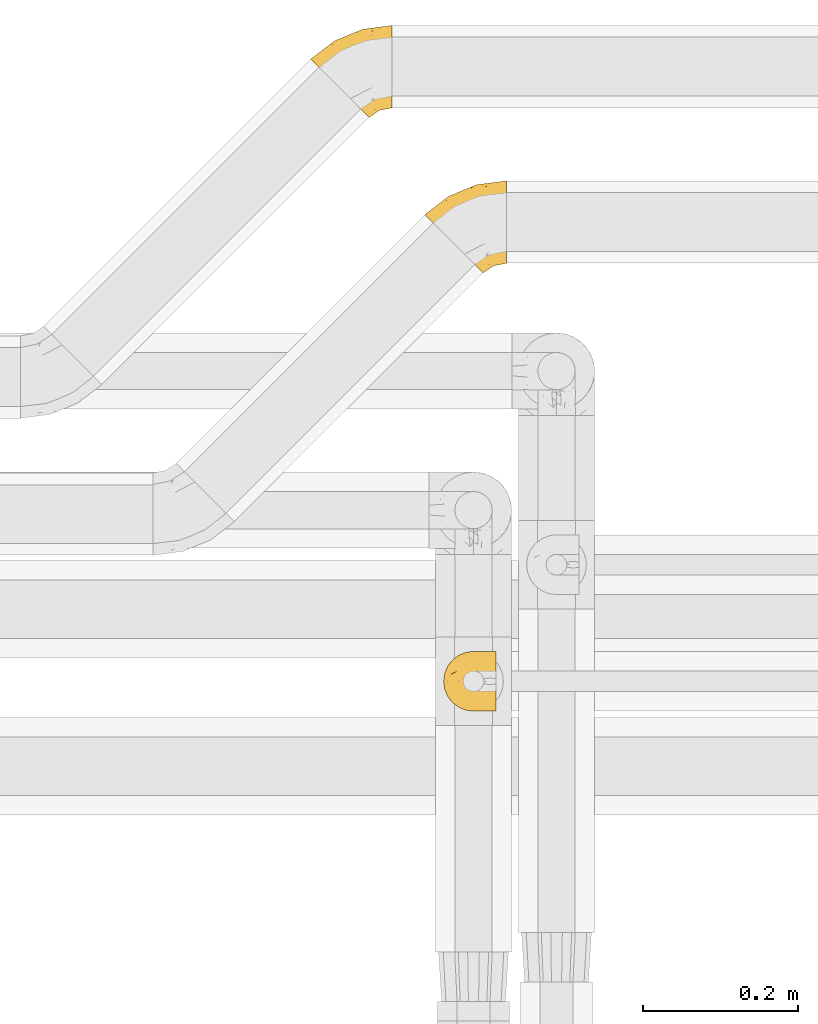
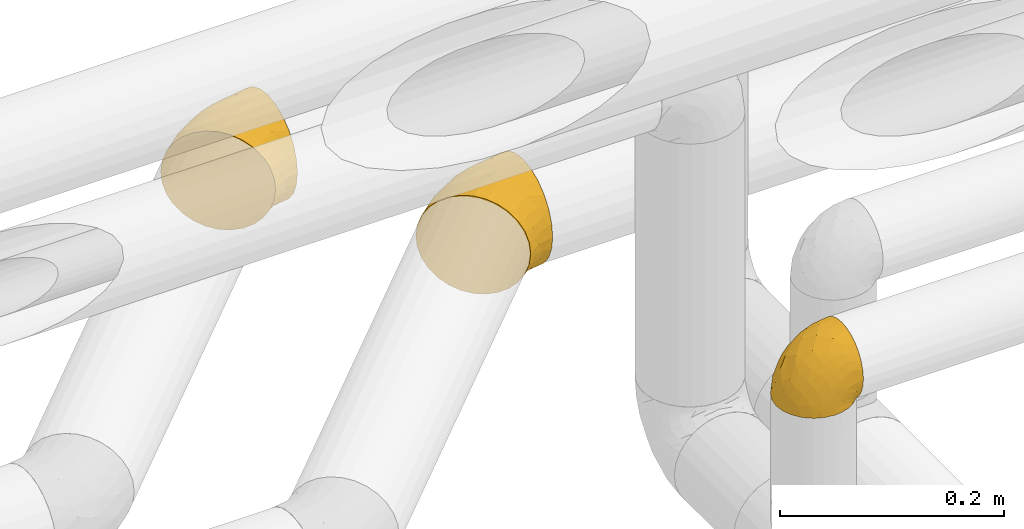
# One storey, part 375 of 827: 3 coverings.
"""IFC2X3 building model written with IfcOpenShell, lengths in millimetres."""

from ifc_helpers import new_model, entity, si_unit, converted_unit, derived_unit, direction, frame, origin, place, context, subcontext, project, spatial, faceted_brep, element, save


model = new_model("IFC2X3")

# Units and contexts
model_context = context("Model", 3, precision=0.01, world=origin(), true_north=direction((6.12303176911189e-17, 1.0)))
body_context = subcontext(model_context, "Body", "Model", "MODEL_VIEW")
ifc_project = project(units=[si_unit("LENGTHUNIT", "METRE", prefix="MILLI"), si_unit("AREAUNIT", "SQUARE_METRE"), si_unit("VOLUMEUNIT", "CUBIC_METRE"), converted_unit("PLANEANGLEUNIT", "DEGREE", entity("IfcRatioMeasure", 0.0174532925199433), si_unit("PLANEANGLEUNIT", "RADIAN"), dimensions=[0, 0, 0, 0, 0, 0, 0]), si_unit("MASSUNIT", "GRAM", prefix="KILO"), derived_unit("MASSDENSITYUNIT", [(si_unit("MASSUNIT", "GRAM", prefix="KILO"), 1), (si_unit("LENGTHUNIT", "METRE"), -3)]), derived_unit("MOMENTOFINERTIAUNIT", [(si_unit("LENGTHUNIT", "METRE"), 4)]), si_unit("TIMEUNIT", "SECOND"), si_unit("FREQUENCYUNIT", "HERTZ"), si_unit("THERMODYNAMICTEMPERATUREUNIT", "DEGREE_CELSIUS"), derived_unit("THERMALTRANSMITTANCEUNIT", [(si_unit("MASSUNIT", "GRAM", prefix="KILO"), 1), (si_unit("THERMODYNAMICTEMPERATUREUNIT", "KELVIN"), -1), (si_unit("TIMEUNIT", "SECOND"), -3)]), derived_unit("VOLUMETRICFLOWRATEUNIT", [(si_unit("LENGTHUNIT", "METRE"), 3), (si_unit("TIMEUNIT", "SECOND"), -1)]), derived_unit("MASSFLOWRATEUNIT", [(si_unit("MASSUNIT", "GRAM", prefix="KILO"), 1), (si_unit("TIMEUNIT", "SECOND"), -1)]), derived_unit("ROTATIONALFREQUENCYUNIT", [(si_unit("TIMEUNIT", "SECOND"), -1)]), si_unit("ELECTRICCURRENTUNIT", "AMPERE"), si_unit("ELECTRICVOLTAGEUNIT", "VOLT"), si_unit("POWERUNIT", "WATT"), si_unit("FORCEUNIT", "NEWTON", prefix="KILO"), si_unit("ILLUMINANCEUNIT", "LUX"), si_unit("LUMINOUSFLUXUNIT", "LUMEN"), si_unit("LUMINOUSINTENSITYUNIT", "CANDELA"), derived_unit("USERDEFINED", [(si_unit("MASSUNIT", "GRAM", prefix="KILO"), -1), (si_unit("LENGTHUNIT", "METRE"), -2), (si_unit("TIMEUNIT", "SECOND"), 3), (si_unit("LUMINOUSFLUXUNIT", "LUMEN"), 1)]), derived_unit("LINEARVELOCITYUNIT", [(si_unit("LENGTHUNIT", "METRE"), 1), (si_unit("TIMEUNIT", "SECOND"), -1)]), si_unit("PRESSUREUNIT", "PASCAL"), derived_unit("USERDEFINED", [(si_unit("LENGTHUNIT", "METRE"), -2), (si_unit("MASSUNIT", "GRAM", prefix="KILO"), 1), (si_unit("TIMEUNIT", "SECOND"), -2)]), derived_unit("LINEARFORCEUNIT", [(si_unit("MASSUNIT", "GRAM", prefix="KILO"), 1), (si_unit("LENGTHUNIT", "METRE"), 1), (si_unit("TIMEUNIT", "SECOND"), -2), (si_unit("LENGTHUNIT", "METRE"), -1)]), derived_unit("PLANARFORCEUNIT", [(si_unit("MASSUNIT", "GRAM", prefix="KILO"), 1), (si_unit("LENGTHUNIT", "METRE"), 1), (si_unit("TIMEUNIT", "SECOND"), -2), (si_unit("LENGTHUNIT", "METRE"), -2)])], contexts=[model_context])

# Site, building, storey
site_placement = place(None, origin())
site = spatial("IfcSite", under=ifc_project, at=site_placement, CompositionType="ELEMENT")
building_placement = place(site_placement, origin())
building = spatial("IfcBuilding", under=site, at=building_placement, CompositionType="ELEMENT")
storey_placement = place(building_placement, frame((0.0, 0.0, 28200.0)))
storey = spatial("IfcBuildingStorey", under=building, at=storey_placement, Name="08", CompositionType="ELEMENT", Elevation=28200.0)

# Coverings
covering_1_placement = place(storey_placement, frame((41305.31, 19240.3, 2945.35)))
element("IfcCovering", 1, at=covering_1_placement, inside=storey, Name=":ADSK_", ObjectType=":ADSK_", PredefinedType="INSULATION", context=body_context, shape_type="Brep", body=[
    faceted_brep([(68.43, 9.78, 87.73), (62.49, 15.73, 96.13), (55.38, 22.84, 102.45), (47.45, 30.77, 106.37), (39.11, 39.11, 107.7), (30.76, 47.46, 106.36), (22.83, 55.39, 102.44), (15.71, 62.5, 96.11), (9.77, 68.44, 87.71), (5.31, 72.91, 77.65), (2.53, 75.68, 66.44), (1.6, 76.62, 54.65), (2.54, 75.68, 42.84), (5.31, 72.9, 31.62), (9.78, 68.43, 21.56), (15.73, 62.49, 13.16), (22.84, 55.38, 6.84), (30.77, 47.45, 2.92), (39.11, 39.11, 1.6), (47.46, 30.76, 2.93), (55.39, 22.83, 6.85), (62.5, 15.71, 13.18), (68.44, 9.77, 21.58), (72.91, 5.31, 31.64), (75.68, 2.53, 42.85), (76.62, 1.6, 54.65), (75.68, 2.54, 66.46), (72.9, 5.31, 77.67), (106.28, 15.69, 40.91), (106.28, 20.99, 28.12), (106.28, 29.42, 17.13), (106.28, 40.41, 8.7), (106.28, 53.2, 3.4), (106.28, 66.93, 1.6), (106.28, 80.66, 3.4), (106.28, 93.46, 8.7), (106.28, 104.44, 17.13), (106.28, 112.87, 28.12), (106.28, 118.17, 40.91), (106.28, 119.98, 54.65), (106.28, 118.17, 68.38), (106.28, 112.87, 81.17), (106.28, 104.44, 92.16), (106.28, 93.46, 100.59), (106.28, 80.66, 105.89), (106.28, 66.93, 107.7), (106.28, 53.2, 105.89), (106.28, 40.41, 100.59), (106.28, 29.42, 92.16), (106.28, 20.99, 81.17), (106.28, 15.69, 68.38), (106.28, 13.88, 54.65), (35.25, 84.78, 91.31), (67.96, 114.94, 54.65), (79.8, 106.99, 86.22), (32.26, 100.15, 54.65), (61.7, 111.08, 68.84), (63.6, 74.97, 105.05), (42.27, 68.02, 103.59), (63.31, 93.39, 95.5), (62.25, 84.29, 101.06), (84.86, 86.35, 103.18), (29.25, 95.13, 71.51), (81.69, 63.7, 107.7), (93.17, 65.21, 107.7), (54.48, 96.92, 89.15), (26.35, 87.27, 82.21), (51.61, 101.66, 81.46), (38.24, 75.94, 98.88), (80.62, 112.86, 76.71), (49.6, 47.16, 107.7), (58.78, 54.2, 107.7), (70.24, 58.95, 107.7), (89.95, 39.42, 101.13), (90.61, 49.04, 105.12), (78.07, 38.94, 102.78), (60.12, 39.02, 105.93), (70.53, 47.55, 106.46), (67.14, 29.5, 101.23), (85.96, 19.64, 85.51), (89.62, 30.55, 95.32), (75.23, 22.77, 94.13), (84.93, 12.06, 73.61), (96.09, 17.3, 76.14), (93.79, 13.16, 65.55), (77.02, 13.53, 84.06), (90.23, 10.69, 54.65), (84.14, 8.35, 63.06), (96.08, 22.06, 84.51), (94.73, 13.37, 44.04), (84.93, 12.05, 35.7), (96.08, 17.3, 33.15), (75.24, 22.76, 15.18), (90.61, 49.04, 4.17), (78.08, 38.92, 6.52), (77.29, 50.26, 2.85), (96.08, 22.06, 24.78), (85.96, 19.62, 23.8), (93.17, 65.21, 1.6), (93.96, 39.19, 8.76), (89.62, 30.53, 13.99), (81.69, 63.7, 1.6), (67.15, 29.49, 8.07), (77.03, 13.52, 25.25), (60.14, 39.02, 3.36), (70.24, 58.95, 1.6), (58.78, 54.2, 1.6), (84.73, 8.8, 45.73), (49.6, 47.16, 1.6), (84.86, 86.35, 6.11), (29.25, 95.12, 37.77), (26.36, 87.26, 27.06), (35.26, 84.77, 17.97), (38.25, 75.93, 10.4), (62.24, 84.29, 8.23), (63.35, 93.4, 13.79), (79.82, 107.0, 23.07), (51.62, 101.65, 27.82), (80.63, 112.86, 32.57), (61.73, 111.09, 40.44), (42.27, 68.0, 5.69), (63.6, 74.97, 4.24)], [[[0, 1, 2, 3, 4, 5, 6, 7, 8, 9, 10, 11, 12, 13, 14, 15, 16, 17, 18, 19, 20, 21, 22, 23, 24, 25, 26, 27]], [[28, 29, 30, 31, 32, 33, 34, 35, 36, 37, 38, 39, 40, 41, 42, 43, 44, 45, 46, 47, 48, 49, 50, 51]], [[52, 8, 7]], [[40, 39, 53]], [[41, 54, 42]], [[53, 55, 56]], [[5, 57, 58]], [[59, 60, 61]], [[55, 10, 62]], [[59, 43, 42]], [[44, 63, 64, 45]], [[63, 44, 57]], [[43, 61, 44]], [[52, 65, 66]], [[54, 59, 42]], [[59, 65, 52]], [[62, 56, 55]], [[62, 67, 56]], [[52, 7, 68]], [[66, 9, 8]], [[66, 62, 9]], [[10, 55, 11]], [[54, 67, 65]], [[69, 54, 41]], [[40, 56, 69]], [[62, 66, 67]], [[68, 7, 6]], [[5, 4, 70, 71]], [[57, 71, 72, 63]], [[57, 5, 71]], [[59, 52, 68]], [[58, 68, 6]], [[60, 57, 61]], [[40, 53, 56]], [[52, 66, 8]], [[62, 10, 9]], [[40, 69, 41]], [[67, 54, 69]], [[67, 69, 56]], [[5, 58, 6]], [[60, 58, 57]], [[59, 61, 43]], [[57, 44, 61]], [[59, 68, 60]], [[58, 60, 68]], [[54, 65, 59]], [[66, 65, 67]], [[73, 48, 47]], [[63, 74, 64]], [[47, 74, 73]], [[74, 75, 73]], [[70, 76, 71]], [[75, 77, 78]], [[79, 80, 81]], [[79, 82, 83]], [[84, 51, 50]], [[49, 83, 50]], [[75, 81, 80]], [[1, 78, 2]], [[27, 85, 0]], [[82, 84, 83]], [[78, 77, 76]], [[77, 63, 72, 71]], [[85, 81, 0]], [[76, 3, 2]], [[78, 76, 2]], [[76, 70, 3]], [[77, 74, 63]], [[74, 46, 64]], [[47, 46, 74]], [[86, 87, 25]], [[86, 84, 87]], [[26, 82, 27]], [[0, 81, 1]], [[80, 88, 48]], [[79, 85, 82]], [[83, 88, 79]], [[70, 4, 3]], [[1, 81, 78]], [[81, 75, 78]], [[76, 77, 71]], [[83, 49, 88]], [[26, 87, 82]], [[51, 84, 86]], [[50, 83, 84]], [[82, 87, 84]], [[25, 87, 26]], [[82, 85, 27]], [[81, 85, 79]], [[48, 88, 49]], [[80, 79, 88]], [[46, 45, 64]], [[75, 80, 73]], [[73, 80, 48]], [[74, 77, 75]], [[89, 90, 91]], [[22, 21, 92]], [[86, 89, 51]], [[93, 94, 95]], [[96, 91, 97]], [[91, 29, 28]], [[93, 98, 32]], [[30, 99, 31]], [[93, 32, 31]], [[30, 29, 96]], [[92, 100, 97]], [[31, 99, 93]], [[93, 95, 101]], [[92, 94, 100]], [[23, 90, 24]], [[21, 102, 92]], [[23, 103, 90]], [[19, 104, 20]], [[92, 97, 103]], [[105, 101, 95, 106]], [[91, 96, 29]], [[103, 23, 22]], [[30, 100, 99]], [[104, 102, 20]], [[107, 90, 89]], [[102, 21, 20]], [[106, 104, 108]], [[104, 19, 108]], [[94, 93, 99]], [[102, 104, 94]], [[19, 18, 108]], [[107, 25, 24]], [[94, 92, 102]], [[95, 104, 106]], [[89, 91, 28]], [[97, 91, 90]], [[51, 89, 28]], [[89, 86, 107]], [[25, 107, 86]], [[24, 90, 107]], [[92, 103, 22]], [[90, 103, 97]], [[97, 100, 96]], [[30, 96, 100]], [[98, 93, 101]], [[98, 33, 32]], [[94, 99, 100]], [[104, 95, 94]], [[35, 34, 109]], [[110, 111, 13]], [[34, 33, 98, 101]], [[112, 113, 15]], [[114, 115, 109]], [[116, 115, 117]], [[39, 38, 53]], [[117, 118, 116]], [[110, 119, 117]], [[115, 116, 36]], [[35, 115, 36]], [[37, 116, 118]], [[118, 117, 119]], [[16, 120, 17]], [[121, 101, 105, 106]], [[112, 111, 117]], [[17, 106, 108, 18]], [[36, 116, 37]], [[112, 15, 14]], [[53, 38, 119]], [[117, 115, 112]], [[121, 34, 101]], [[118, 38, 37]], [[113, 16, 15]], [[119, 110, 55]], [[111, 14, 13]], [[12, 11, 55]], [[12, 55, 110]], [[120, 16, 113]], [[111, 110, 117]], [[119, 55, 53]], [[12, 110, 13]], [[111, 112, 14]], [[17, 121, 106]], [[112, 115, 113]], [[109, 115, 35]], [[38, 118, 119]], [[114, 120, 113]], [[17, 120, 121]], [[34, 121, 109]], [[109, 121, 114]], [[120, 114, 121]], [[113, 115, 114]]]),
])
covering_2_placement = place(storey_placement, frame((41158.29, 19440.3, 2945.35)))
element("IfcCovering", 2, at=covering_2_placement, inside=storey, Name=":ADSK_", ObjectType=":ADSK_", PredefinedType="INSULATION", context=body_context, shape_type="Brep", body=[
    faceted_brep([(68.43, 9.78, 87.73), (62.49, 15.73, 96.13), (55.38, 22.84, 102.45), (47.45, 30.77, 106.37), (39.11, 39.11, 107.7), (30.76, 47.46, 106.36), (22.83, 55.39, 102.44), (15.71, 62.5, 96.11), (9.77, 68.44, 87.71), (5.31, 72.91, 77.65), (2.53, 75.68, 66.44), (1.6, 76.62, 54.65), (2.54, 75.68, 42.84), (5.31, 72.9, 31.62), (9.78, 68.43, 21.56), (15.73, 62.49, 13.16), (22.84, 55.38, 6.84), (30.77, 47.45, 2.92), (39.11, 39.11, 1.6), (47.46, 30.76, 2.93), (55.39, 22.83, 6.85), (62.5, 15.71, 13.18), (68.44, 9.77, 21.58), (72.91, 5.31, 31.64), (75.68, 2.53, 42.85), (76.62, 1.6, 54.65), (75.68, 2.54, 66.46), (72.9, 5.31, 77.67), (106.28, 15.69, 40.91), (106.28, 20.99, 28.12), (106.28, 29.42, 17.13), (106.28, 40.41, 8.7), (106.28, 53.2, 3.4), (106.28, 66.93, 1.6), (106.28, 80.66, 3.4), (106.28, 93.46, 8.7), (106.28, 104.44, 17.13), (106.28, 112.87, 28.12), (106.28, 118.17, 40.91), (106.28, 119.98, 54.65), (106.28, 118.17, 68.38), (106.28, 112.87, 81.17), (106.28, 104.44, 92.16), (106.28, 93.46, 100.59), (106.28, 80.66, 105.89), (106.28, 66.93, 107.7), (106.28, 53.2, 105.89), (106.28, 40.41, 100.59), (106.28, 29.42, 92.16), (106.28, 20.99, 81.17), (106.28, 15.69, 68.38), (106.28, 13.88, 54.65), (35.25, 84.78, 91.31), (67.96, 114.94, 54.65), (79.8, 106.99, 86.22), (32.26, 100.15, 54.65), (61.7, 111.08, 68.84), (63.6, 74.97, 105.05), (42.27, 68.02, 103.59), (63.31, 93.39, 95.5), (62.25, 84.29, 101.06), (84.86, 86.35, 103.18), (29.25, 95.13, 71.51), (81.69, 63.7, 107.7), (93.17, 65.21, 107.7), (54.48, 96.92, 89.15), (26.35, 87.27, 82.21), (51.61, 101.66, 81.46), (38.24, 75.94, 98.88), (80.62, 112.86, 76.71), (49.6, 47.16, 107.7), (58.78, 54.2, 107.7), (70.24, 58.95, 107.7), (89.95, 39.42, 101.13), (90.61, 49.04, 105.12), (78.07, 38.94, 102.78), (60.12, 39.02, 105.93), (70.53, 47.55, 106.46), (67.14, 29.5, 101.23), (85.96, 19.64, 85.51), (89.62, 30.55, 95.32), (75.23, 22.77, 94.13), (84.93, 12.06, 73.61), (96.09, 17.3, 76.14), (93.79, 13.16, 65.55), (77.02, 13.53, 84.06), (90.23, 10.69, 54.65), (84.14, 8.35, 63.06), (96.08, 22.06, 84.51), (94.73, 13.37, 44.04), (84.93, 12.05, 35.7), (96.08, 17.3, 33.15), (75.24, 22.76, 15.18), (90.61, 49.04, 4.17), (78.08, 38.92, 6.52), (77.29, 50.26, 2.85), (96.08, 22.06, 24.78), (85.96, 19.62, 23.8), (93.17, 65.21, 1.6), (93.96, 39.19, 8.76), (89.62, 30.53, 13.99), (81.69, 63.7, 1.6), (67.15, 29.49, 8.07), (77.03, 13.52, 25.25), (60.14, 39.02, 3.36), (70.24, 58.95, 1.6), (58.78, 54.2, 1.6), (84.73, 8.8, 45.73), (49.6, 47.16, 1.6), (84.86, 86.35, 6.11), (29.25, 95.12, 37.77), (26.36, 87.26, 27.06), (35.26, 84.77, 17.97), (38.25, 75.93, 10.4), (62.24, 84.29, 8.23), (63.35, 93.4, 13.79), (79.82, 107.0, 23.07), (51.62, 101.65, 27.82), (80.63, 112.86, 32.57), (61.73, 111.09, 40.44), (42.27, 68.0, 5.69), (63.6, 74.97, 4.24)], [[[0, 1, 2, 3, 4, 5, 6, 7, 8, 9, 10, 11, 12, 13, 14, 15, 16, 17, 18, 19, 20, 21, 22, 23, 24, 25, 26, 27]], [[28, 29, 30, 31, 32, 33, 34, 35, 36, 37, 38, 39, 40, 41, 42, 43, 44, 45, 46, 47, 48, 49, 50, 51]], [[52, 8, 7]], [[40, 39, 53]], [[41, 54, 42]], [[53, 55, 56]], [[5, 57, 58]], [[59, 60, 61]], [[55, 10, 62]], [[59, 43, 42]], [[44, 63, 64, 45]], [[63, 44, 57]], [[43, 61, 44]], [[52, 65, 66]], [[54, 59, 42]], [[59, 65, 52]], [[62, 56, 55]], [[62, 67, 56]], [[52, 7, 68]], [[66, 9, 8]], [[66, 62, 9]], [[10, 55, 11]], [[54, 67, 65]], [[69, 54, 41]], [[40, 56, 69]], [[62, 66, 67]], [[68, 7, 6]], [[5, 4, 70, 71]], [[57, 71, 72, 63]], [[57, 5, 71]], [[59, 52, 68]], [[58, 68, 6]], [[60, 57, 61]], [[40, 53, 56]], [[52, 66, 8]], [[62, 10, 9]], [[40, 69, 41]], [[67, 54, 69]], [[67, 69, 56]], [[5, 58, 6]], [[60, 58, 57]], [[59, 61, 43]], [[57, 44, 61]], [[59, 68, 60]], [[58, 60, 68]], [[54, 65, 59]], [[66, 65, 67]], [[73, 48, 47]], [[63, 74, 64]], [[47, 74, 73]], [[74, 75, 73]], [[70, 76, 71]], [[75, 77, 78]], [[79, 80, 81]], [[79, 82, 83]], [[84, 51, 50]], [[49, 83, 50]], [[75, 81, 80]], [[1, 78, 2]], [[27, 85, 0]], [[82, 84, 83]], [[78, 77, 76]], [[77, 63, 72, 71]], [[85, 81, 0]], [[76, 3, 2]], [[78, 76, 2]], [[76, 70, 3]], [[77, 74, 63]], [[74, 46, 64]], [[47, 46, 74]], [[86, 87, 25]], [[86, 84, 87]], [[26, 82, 27]], [[0, 81, 1]], [[80, 88, 48]], [[79, 85, 82]], [[83, 88, 79]], [[70, 4, 3]], [[1, 81, 78]], [[81, 75, 78]], [[76, 77, 71]], [[83, 49, 88]], [[26, 87, 82]], [[51, 84, 86]], [[50, 83, 84]], [[82, 87, 84]], [[25, 87, 26]], [[82, 85, 27]], [[81, 85, 79]], [[48, 88, 49]], [[80, 79, 88]], [[46, 45, 64]], [[75, 80, 73]], [[73, 80, 48]], [[74, 77, 75]], [[89, 90, 91]], [[22, 21, 92]], [[86, 89, 51]], [[93, 94, 95]], [[96, 91, 97]], [[91, 29, 28]], [[93, 98, 32]], [[30, 99, 31]], [[93, 32, 31]], [[30, 29, 96]], [[92, 100, 97]], [[31, 99, 93]], [[93, 95, 101]], [[92, 94, 100]], [[23, 90, 24]], [[21, 102, 92]], [[23, 103, 90]], [[19, 104, 20]], [[92, 97, 103]], [[105, 101, 95, 106]], [[91, 96, 29]], [[103, 23, 22]], [[30, 100, 99]], [[104, 102, 20]], [[107, 90, 89]], [[102, 21, 20]], [[106, 104, 108]], [[104, 19, 108]], [[94, 93, 99]], [[102, 104, 94]], [[19, 18, 108]], [[107, 25, 24]], [[94, 92, 102]], [[95, 104, 106]], [[89, 91, 28]], [[97, 91, 90]], [[51, 89, 28]], [[89, 86, 107]], [[25, 107, 86]], [[24, 90, 107]], [[92, 103, 22]], [[90, 103, 97]], [[97, 100, 96]], [[30, 96, 100]], [[98, 93, 101]], [[98, 33, 32]], [[94, 99, 100]], [[104, 95, 94]], [[35, 34, 109]], [[110, 111, 13]], [[34, 33, 98, 101]], [[112, 113, 15]], [[114, 115, 109]], [[116, 115, 117]], [[39, 38, 53]], [[117, 118, 116]], [[110, 119, 117]], [[115, 116, 36]], [[35, 115, 36]], [[37, 116, 118]], [[118, 117, 119]], [[16, 120, 17]], [[121, 101, 105, 106]], [[112, 111, 117]], [[17, 106, 108, 18]], [[36, 116, 37]], [[112, 15, 14]], [[53, 38, 119]], [[117, 115, 112]], [[121, 34, 101]], [[118, 38, 37]], [[113, 16, 15]], [[119, 110, 55]], [[111, 14, 13]], [[12, 11, 55]], [[12, 55, 110]], [[120, 16, 113]], [[111, 110, 117]], [[119, 55, 53]], [[12, 110, 13]], [[111, 112, 14]], [[17, 121, 106]], [[112, 115, 113]], [[109, 115, 35]], [[38, 118, 119]], [[114, 120, 113]], [[17, 120, 121]], [[34, 121, 109]], [[109, 121, 114]], [[120, 114, 121]], [[113, 115, 114]]]),
])
covering_3_placement = place(storey_placement, frame((41329.33, 18676.18, 3169.25)))
element("IfcCovering", 3, at=covering_3_placement, inside=storey, Name=":ADSK_", ObjectType=":ADSK_", PredefinedType="INSULATION", context=body_context, shape_type="Brep", body=[
    faceted_brep([(69.15, 14.62, 1.85), (69.15, 16.82, 1.85), (69.15, 18.56, 1.85), (69.15, 20.52, 1.85), (69.15, 22.49, 1.85), (69.15, 24.46, 1.85), (69.15, 26.42, 1.85), (69.15, 28.39, 1.85), (69.15, 30.36, 1.85), (69.15, 32.55, 1.85), (69.15, 34.75, 1.85), (69.15, 36.94, 1.85), (69.15, 39.13, 1.85), (69.15, 41.33, 1.85), (69.15, 43.52, 1.85), (69.15, 45.72, 1.85), (69.15, 47.91, 1.85), (69.15, 50.11, 1.85), (69.15, 52.3, 1.85), (69.15, 54.49, 1.85), (69.15, 56.69, 1.85), (69.15, 58.88, 1.85), (69.15, 61.08, 1.85), (69.15, 63.27, 1.85), (69.15, 65.47, 1.85), (69.14, 70.97, 7.85), (69.14, 75.09, 14.88), (69.14, 77.64, 22.61), (69.14, 78.5, 30.7), (69.14, 77.53, 39.26), (69.14, 74.68, 47.38), (69.14, 70.1, 54.67), (69.14, 64.01, 60.76), (69.14, 56.72, 65.34), (69.14, 48.6, 68.18), (69.14, 40.05, 69.15), (69.14, 31.49, 68.18), (69.14, 23.36, 65.33), (69.14, 16.07, 60.75), (69.14, 9.98, 54.66), (69.14, 5.4, 47.37), (69.14, 2.56, 39.25), (69.14, 1.6, 30.7), (69.14, 2.46, 22.59), (69.14, 5.01, 14.86), (69.14, 9.13, 7.84), (68.89, 14.62, 1.6), (62.89, 9.12, 1.6), (55.87, 5.0, 1.6), (48.14, 2.46, 1.6), (40.05, 1.6, 1.6), (30.09, 2.91, 1.6), (20.82, 6.75, 1.6), (12.86, 12.86, 1.6), (6.75, 20.82, 1.6), (2.91, 30.09, 1.6), (1.6, 40.05, 1.6), (2.91, 50.0, 1.6), (6.75, 59.27, 1.6), (12.86, 67.23, 1.6), (20.82, 73.34, 1.6), (30.09, 77.19, 1.6), (40.05, 78.5, 1.6), (48.14, 77.63, 1.6), (55.87, 75.09, 1.6), (62.89, 70.97, 1.6), (68.89, 65.47, 1.6), (68.89, 63.27, 1.6), (68.89, 62.29, 1.6), (68.89, 60.7, 1.6), (68.89, 59.11, 1.6), (68.89, 57.52, 1.6), (68.89, 55.93, 1.6), (68.89, 54.34, 1.6), (68.89, 52.76, 1.6), (68.89, 51.17, 1.6), (68.89, 49.58, 1.6), (68.89, 47.99, 1.6), (68.89, 46.4, 1.6), (68.89, 44.81, 1.6), (68.89, 43.22, 1.6), (68.89, 41.63, 1.6), (68.89, 40.05, 1.6), (68.89, 38.46, 1.6), (68.89, 36.87, 1.6), (68.89, 35.28, 1.6), (68.89, 33.69, 1.6), (68.89, 32.1, 1.6), (68.89, 30.51, 1.6), (68.89, 28.92, 1.6), (68.89, 27.33, 1.6), (68.89, 25.37, 1.6), (68.89, 23.4, 1.6), (68.89, 21.21, 1.6), (68.89, 19.01, 1.6), (68.89, 16.82, 1.6), (68.97, 42.32, 1.78), (68.96, 44.02, 1.77), (68.97, 47.13, 1.78), (68.97, 48.74, 1.77), (68.98, 23.57, 1.79), (68.97, 25.13, 1.78), (68.96, 61.34, 1.76), (68.96, 22.02, 1.77), (68.96, 29.72, 1.77), (68.96, 56.73, 1.76), (68.96, 55.14, 1.77), (68.96, 37.66, 1.77), (69.0, 64.12, 1.8), (68.96, 28.13, 1.76), (68.96, 26.62, 1.77), (68.97, 31.46, 1.78), (68.96, 16.16, 1.77), (68.96, 39.16, 1.77), (68.96, 50.37, 1.76), (68.97, 17.69, 1.77), (68.97, 19.17, 1.78), (68.97, 62.78, 1.77), (68.96, 58.35, 1.77), (68.96, 45.53, 1.77), (68.97, 59.91, 1.78), (68.97, 65.47, 1.77), (69.02, 65.47, 1.8), (69.08, 65.47, 1.82), (68.97, 14.62, 1.77), (68.94, 14.62, 1.72), (68.92, 14.62, 1.66), (68.96, 20.59, 1.76), (68.96, 32.99, 1.77), (68.95, 34.48, 1.76), (68.96, 51.91, 1.77), (68.92, 65.47, 1.66), (68.94, 65.47, 1.72), (68.98, 53.48, 1.78), (69.08, 14.62, 1.82), (69.02, 14.62, 1.8), (68.96, 40.77, 1.77), (68.97, 35.97, 1.78), (61.33, 7.84, 3.72), (53.1, 3.53, 7.41), (63.33, 8.32, 6.13), (49.27, 1.6, 21.47), (55.53, 2.19, 19.34), (54.59, 1.6, 26.8), (41.99, 1.6, 8.87), (57.07, 4.57, 9.2), (57.95, 3.96, 12.79), (51.56, 2.28, 14.62), (41.58, 1.6, 7.34), (61.7, 7.69, 5.33), (63.33, 3.53, 17.64), (65.0, 8.32, 7.7), (67.02, 7.84, 9.41), (61.87, 1.6, 28.75), (43.94, 1.6, 16.14), (61.21, 4.34, 14.14), (63.4, 1.6, 29.16), (33.1, 29.63, 57.02), (52.82, 27.34, 64.91), (43.29, 40.05, 64.0), (33.73, 2.39, 11.92), (36.52, 2.43, 19.16), (24.87, 9.07, 28.65), (14.17, 16.64, 24.62), (18.43, 9.54, 15.18), (28.67, 4.52, 18.36), (26.0, 4.52, 9.2), (49.25, 7.49, 46.98), (59.72, 7.49, 50.24), (55.09, 12.85, 56.1), (44.71, 2.35, 28.97), (34.14, 22.66, 54.45), (5.25, 32.9, 21.34), (6.75, 25.33, 18.4), (55.54, 40.05, 66.44), (10.47, 16.64, 12.07), (25.49, 19.99, 45.48), (35.53, 16.37, 50.56), (48.21, 3.26, 36.04), (58.71, 3.75, 42.07), (57.42, 19.58, 62.12), (34.83, 7.5, 37.37), (36.87, 4.04, 29.38), (45.0, 13.94, 53.59), (44.39, 19.58, 58.06), (23.96, 28.21, 49.26), (11.2, 24.75, 29.63), (10.56, 31.42, 33.21), (16.81, 26.2, 40.1), (17.38, 33.36, 44.07), (21.38, 40.05, 49.36), (32.33, 40.05, 56.68), (4.3, 40.05, 15.2), (20.65, 16.14, 35.57), (29.66, 12.85, 41.7), (39.6, 10.46, 46.39), (42.55, 6.49, 41.4), (6.74, 40.05, 27.44), (14.06, 40.05, 38.4), (26.84, 75.57, 12.99), (5.28, 47.37, 21.33), (18.52, 52.91, 42.89), (33.12, 50.46, 57.03), (55.09, 67.23, 56.11), (57.42, 60.5, 62.13), (20.72, 70.55, 21.89), (11.46, 63.45, 16.62), (17.69, 62.61, 32.9), (49.25, 72.6, 46.99), (59.72, 72.6, 50.25), (58.71, 76.34, 42.08), (29.72, 59.34, 49.91), (35.35, 77.76, 15.59), (43.94, 78.5, 16.14), (41.99, 78.5, 8.87), (63.4, 78.5, 29.16), (4.93, 53.16, 13.16), (17.46, 70.55, 10.83), (10.94, 48.88, 33.8), (8.92, 54.76, 25.02), (52.82, 52.74, 64.92), (29.34, 71.93, 32.83), (30.26, 75.79, 20.56), (44.4, 60.5, 58.07), (39.06, 77.86, 21.46), (43.06, 77.64, 28.1), (54.59, 78.5, 26.8), (49.27, 78.5, 21.47), (42.69, 67.23, 51.28), (48.2, 76.82, 36.04), (61.87, 78.5, 28.75), (33.44, 77.8, 8.45), (29.66, 67.23, 41.72), (38.5, 73.2, 39.27), (23.34, 67.66, 33.56), (34.97, 75.99, 27.29), (53.1, 76.57, 7.41), (59.68, 73.21, 3.51), (62.19, 71.93, 4.68), (64.11, 71.07, 5.52), (57.97, 75.09, 8.75), (57.95, 76.13, 12.79), (63.33, 76.57, 17.65), (51.77, 77.69, 13.9), (67.02, 72.26, 9.41), (64.98, 71.77, 7.68), (55.53, 77.9, 19.33), (61.22, 75.75, 14.13)], [[[0, 1, 2, 3, 4, 5, 6, 7, 8, 9, 10, 11, 12, 13, 14, 15, 16, 17, 18, 19, 20, 21, 22, 23, 24, 25, 26, 27, 28, 29, 30, 31, 32, 33, 34, 35, 36, 37, 38, 39, 40, 41, 42, 43, 44, 45]], [[46, 47, 48, 49, 50, 51, 52, 53, 54, 55, 56, 57, 58, 59, 60, 61, 62, 63, 64, 65, 66, 67, 68, 69, 70, 71, 72, 73, 74, 75, 76, 77, 78, 79, 80, 81, 82, 83, 84, 85, 86, 87, 88, 89, 90, 91, 92, 93, 94, 95]], [[96, 97, 14]], [[98, 77, 99]], [[100, 101, 5]], [[69, 68, 102]], [[4, 3, 103]], [[8, 7, 104]], [[4, 103, 100]], [[72, 105, 106]], [[84, 83, 107]], [[89, 88, 104]], [[108, 67, 66]], [[109, 110, 90]], [[111, 9, 8]], [[112, 1, 0]], [[82, 113, 83]], [[109, 7, 6]], [[114, 76, 75]], [[105, 20, 106]], [[104, 111, 8]], [[2, 115, 116]], [[97, 96, 80]], [[67, 108, 117]], [[105, 71, 118]], [[15, 97, 119]], [[102, 120, 69]], [[108, 121, 122, 123, 24]], [[112, 95, 115]], [[1, 115, 2]], [[94, 116, 115]], [[117, 68, 67]], [[22, 117, 23]], [[112, 124, 125, 126, 46]], [[1, 112, 115]], [[70, 120, 118]], [[23, 117, 108]], [[120, 22, 21]], [[120, 21, 118]], [[120, 70, 69]], [[116, 94, 127]], [[128, 86, 129]], [[117, 22, 102]], [[74, 130, 75]], [[99, 17, 16]], [[115, 95, 94]], [[23, 108, 24]], [[108, 66, 131, 132, 121]], [[105, 72, 71]], [[118, 21, 20]], [[71, 70, 118]], [[19, 106, 20]], [[20, 105, 118]], [[19, 133, 106]], [[74, 73, 133]], [[106, 133, 73]], [[99, 114, 17]], [[133, 19, 18]], [[73, 72, 106]], [[95, 112, 46]], [[112, 0, 134, 135, 124]], [[130, 114, 75]], [[99, 76, 114]], [[114, 130, 17]], [[18, 17, 130]], [[78, 77, 98]], [[98, 119, 78]], [[130, 133, 18]], [[133, 130, 74]], [[79, 97, 80]], [[98, 99, 16]], [[98, 16, 15]], [[77, 76, 99]], [[97, 79, 119]], [[136, 96, 13]], [[14, 97, 15]], [[136, 13, 12]], [[81, 80, 96]], [[13, 96, 14]], [[15, 119, 98]], [[119, 79, 78]], [[96, 136, 81]], [[82, 81, 136]], [[113, 107, 83]], [[84, 107, 137]], [[107, 11, 137]], [[113, 12, 107]], [[11, 107, 12]], [[85, 84, 137]], [[137, 11, 10]], [[113, 136, 12]], [[136, 113, 82]], [[109, 89, 104]], [[86, 85, 129]], [[89, 109, 90]], [[111, 87, 128]], [[10, 129, 137]], [[88, 111, 104]], [[9, 111, 128]], [[6, 110, 109]], [[7, 109, 104]], [[110, 91, 90]], [[100, 92, 101]], [[110, 6, 101]], [[91, 110, 101]], [[116, 3, 2]], [[111, 88, 87]], [[127, 103, 3]], [[9, 128, 10]], [[86, 128, 87]], [[128, 129, 10]], [[137, 129, 85]], [[120, 102, 22]], [[117, 102, 68]], [[91, 101, 92]], [[5, 101, 6]], [[93, 92, 103]], [[100, 5, 4]], [[100, 103, 92]], [[127, 93, 103]], [[93, 127, 94]], [[116, 127, 3]], [[126, 138, 47]], [[48, 138, 139]], [[140, 125, 124]], [[141, 142, 143]], [[144, 49, 139]], [[145, 140, 146]], [[48, 139, 49]], [[139, 145, 147]], [[49, 144, 148, 50]], [[126, 125, 149]], [[44, 43, 150]], [[151, 146, 140]], [[149, 140, 145]], [[152, 151, 135]], [[152, 44, 150]], [[0, 45, 134]], [[43, 153, 150]], [[124, 151, 140]], [[141, 147, 142]], [[44, 152, 45]], [[45, 152, 134]], [[47, 46, 126]], [[139, 154, 144]], [[138, 48, 47]], [[125, 140, 149]], [[135, 134, 152]], [[146, 155, 142]], [[145, 146, 147]], [[149, 139, 138]], [[147, 141, 154]], [[147, 146, 142]], [[139, 147, 154]], [[139, 149, 145]], [[149, 138, 126]], [[155, 146, 151]], [[150, 143, 142]], [[152, 155, 151]], [[150, 142, 155]], [[43, 42, 156, 153]], [[153, 143, 150]], [[152, 150, 155]], [[151, 124, 135]], [[157, 158, 159]], [[160, 154, 161]], [[162, 163, 164]], [[165, 166, 160]], [[167, 168, 169]], [[141, 170, 161]], [[156, 42, 41]], [[158, 157, 171]], [[172, 55, 173]], [[158, 36, 174]], [[175, 54, 53]], [[52, 166, 164]], [[52, 164, 53]], [[54, 175, 173]], [[166, 52, 51]], [[176, 177, 171]], [[178, 143, 179]], [[156, 41, 179]], [[38, 37, 180]], [[169, 39, 38]], [[179, 143, 153, 156]], [[179, 41, 40]], [[168, 179, 40]], [[181, 162, 182]], [[179, 167, 178]], [[183, 184, 177]], [[183, 169, 184]], [[176, 171, 185]], [[172, 186, 187]], [[158, 37, 36]], [[159, 158, 174]], [[184, 180, 158]], [[54, 173, 55]], [[180, 169, 38]], [[188, 189, 187]], [[39, 168, 40]], [[186, 188, 187]], [[190, 157, 159, 191]], [[55, 172, 192]], [[176, 193, 194]], [[161, 170, 182]], [[51, 50, 148]], [[162, 164, 165]], [[175, 164, 163]], [[167, 195, 196]], [[178, 182, 170]], [[36, 35, 174]], [[158, 180, 37]], [[169, 180, 184]], [[169, 168, 39]], [[179, 168, 167]], [[182, 162, 165]], [[162, 194, 193]], [[161, 165, 160]], [[195, 181, 196]], [[192, 172, 197]], [[192, 56, 55]], [[189, 190, 198]], [[198, 197, 187]], [[172, 187, 197]], [[185, 189, 188]], [[198, 187, 189]], [[186, 172, 173]], [[173, 163, 186]], [[193, 186, 163]], [[176, 185, 188]], [[185, 157, 190]], [[188, 186, 193]], [[177, 176, 194]], [[188, 193, 176]], [[162, 193, 163]], [[195, 177, 194]], [[171, 177, 184]], [[181, 195, 194]], [[183, 167, 169]], [[162, 181, 194]], [[196, 182, 178]], [[158, 171, 184]], [[171, 157, 185]], [[177, 195, 183]], [[167, 183, 195]], [[182, 196, 181]], [[178, 170, 143]], [[178, 167, 196]], [[164, 175, 53]], [[173, 175, 163]], [[160, 51, 148]], [[164, 166, 165]], [[51, 160, 166]], [[160, 148, 144, 154]], [[141, 161, 154]], [[182, 165, 161]], [[190, 189, 185]], [[143, 170, 141]], [[60, 199, 61]], [[197, 200, 192]], [[201, 190, 202]], [[200, 57, 192]], [[203, 204, 32]], [[205, 206, 207]], [[208, 209, 210]], [[211, 207, 201]], [[212, 213, 214]], [[29, 215, 210]], [[216, 206, 58]], [[29, 28, 215]], [[59, 217, 60]], [[60, 217, 199]], [[30, 29, 210]], [[218, 201, 219]], [[202, 159, 220]], [[205, 221, 222]], [[223, 204, 203]], [[31, 203, 32]], [[57, 200, 216]], [[220, 33, 204]], [[220, 174, 34]], [[31, 30, 209]], [[212, 224, 213]], [[225, 226, 227]], [[228, 223, 203]], [[208, 210, 229]], [[210, 226, 229]], [[33, 220, 34]], [[58, 206, 59]], [[209, 203, 31]], [[202, 220, 223]], [[228, 203, 208]], [[202, 211, 201]], [[33, 32, 204]], [[202, 190, 191, 159]], [[210, 215, 230, 226]], [[199, 212, 231]], [[232, 233, 221]], [[233, 208, 229]], [[207, 206, 219]], [[217, 206, 205]], [[227, 224, 225]], [[233, 232, 228]], [[201, 207, 219]], [[234, 232, 221]], [[218, 219, 200]], [[202, 223, 211]], [[174, 220, 159]], [[174, 35, 34]], [[61, 231, 62]], [[220, 204, 223]], [[210, 209, 30]], [[203, 209, 208]], [[225, 233, 229]], [[224, 227, 213]], [[221, 233, 235]], [[57, 56, 192]], [[198, 218, 197]], [[200, 219, 216]], [[201, 198, 190]], [[197, 218, 200]], [[198, 201, 218]], [[206, 216, 219]], [[58, 57, 216]], [[231, 212, 214]], [[222, 212, 199]], [[228, 211, 223]], [[207, 211, 232]], [[62, 231, 214]], [[199, 231, 61]], [[233, 228, 208]], [[211, 228, 232]], [[222, 221, 235]], [[234, 205, 207]], [[206, 217, 59]], [[199, 217, 205]], [[205, 222, 199]], [[224, 222, 235]], [[222, 224, 212]], [[224, 235, 225]], [[233, 225, 235]], [[226, 225, 229]], [[205, 234, 221]], [[207, 232, 234]], [[63, 214, 236]], [[214, 213, 236]], [[214, 63, 62]], [[237, 236, 238]], [[238, 132, 131]], [[236, 237, 64]], [[239, 240, 241]], [[63, 236, 64]], [[131, 66, 65]], [[237, 131, 65]], [[242, 230, 27]], [[237, 65, 64]], [[239, 121, 132]], [[26, 242, 27]], [[241, 240, 243]], [[25, 123, 244]], [[27, 230, 215, 28]], [[244, 122, 245]], [[227, 246, 243]], [[241, 243, 246]], [[121, 239, 245]], [[25, 24, 123]], [[132, 238, 239]], [[244, 26, 25]], [[131, 237, 238]], [[240, 239, 238]], [[245, 239, 241]], [[247, 241, 246]], [[247, 244, 245]], [[238, 236, 240]], [[243, 236, 213]], [[236, 243, 240]], [[226, 246, 227]], [[243, 213, 227]], [[226, 242, 246]], [[241, 247, 245]], [[246, 242, 247]], [[244, 247, 242]], [[242, 226, 230]], [[26, 244, 242]], [[122, 244, 123]], [[122, 121, 245]]]),
])

save(model, "model.ifc")
